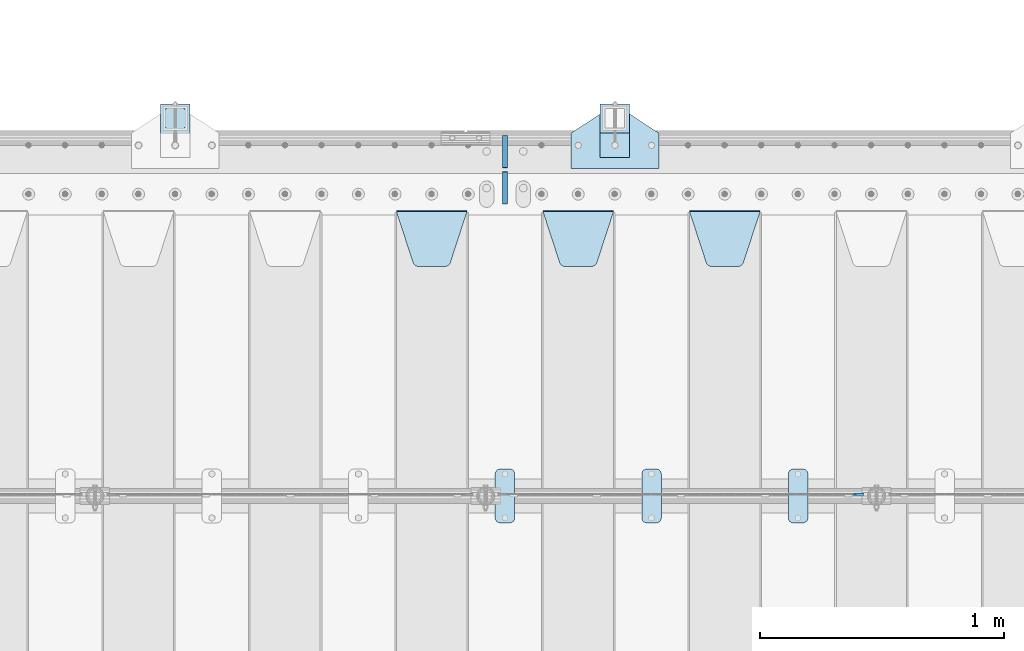
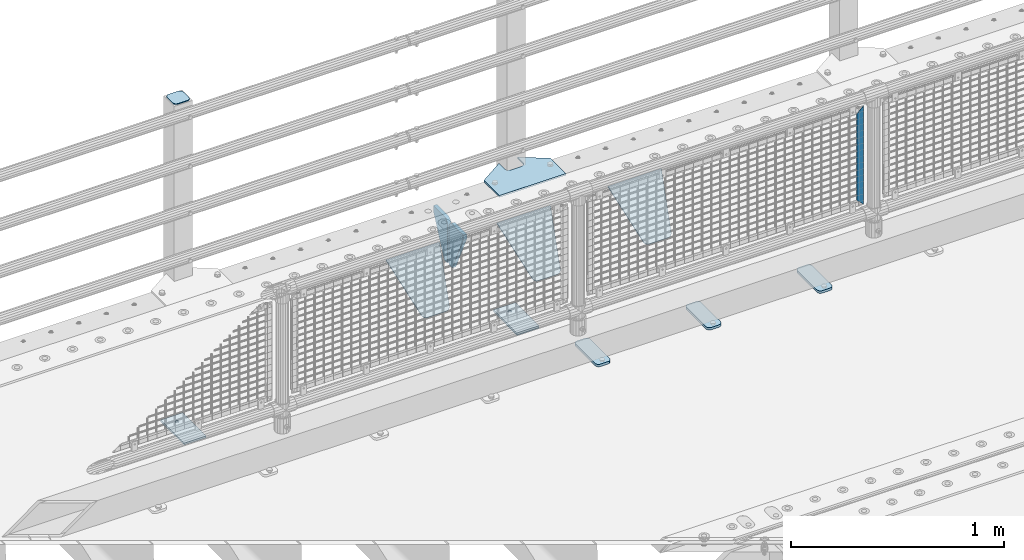
# One storey, part 216 of 247: 14 plates.
"""IFC2X3 building model written with IfcOpenShell, lengths in millimetres."""

from ifc_helpers import new_model, si_unit, frame, origin_with_axes, place, context, subcontext, project, spatial, faceted_brep, material, type_object, element, save


model = new_model("IFC2X3")

# Units and contexts
model_context = context("Model", 3, precision=1e-05, world=origin_with_axes())
body_context = subcontext(model_context, "Body", "Model", "MODEL_VIEW")
ifc_project = project(units=[si_unit("LENGTHUNIT", "METRE", prefix="MILLI"), si_unit("AREAUNIT", "SQUARE_METRE"), si_unit("VOLUMEUNIT", "CUBIC_METRE"), si_unit("MASSUNIT", "GRAM", prefix="KILO"), si_unit("TIMEUNIT", "SECOND"), si_unit("PLANEANGLEUNIT", "RADIAN"), si_unit("SOLIDANGLEUNIT", "STERADIAN"), si_unit("THERMODYNAMICTEMPERATUREUNIT", "DEGREE_CELSIUS"), si_unit("LUMINOUSINTENSITYUNIT", "LUMEN")], contexts=[model_context])

# Site, building, storey
site_placement = place(None, origin_with_axes())
site = spatial("IfcSite", under=ifc_project, at=site_placement, CompositionType="ELEMENT")
building_placement = place(site_placement, origin_with_axes())
building = spatial("IfcBuilding", under=site, at=building_placement, Name="Standard", CompositionType="ELEMENT")
storey_placement = place(building_placement, origin_with_axes())
storey = spatial("IfcBuildingStorey", under=building, at=storey_placement, Name="Undefined", CompositionType="ELEMENT", Elevation=0.0)

# Plates
ifc_material_1 = material(Name="STEEL/S355J2")
plate_type_1 = type_object("IfcPlateType", PredefinedType="NOTDEFINED")
plate_1_placement = place(storey_placement, frame((6660.0, 7774.5, 21.0199999999977), z_axis=(1.0, 0.0, 0.0), x_axis=(0.0, -0.999999999999548, -9.5100000000016e-07)))
element("IfcPlate", 1, at=plate_1_placement, inside=storey, type_object=plate_type_1, material=ifc_material_1, context=body_context, shape_type="Brep", body=[
    faceted_brep([(0.0, -7.0, 20.0), (0.0, -7.0, 60.0), (0.0, 7.0, 60.0), (0.0, 7.0, 20.0), (0.384294391935327, -7.0, 63.9018064403226), (0.384294391935327, 7.0, 63.9018064403226), (1.52240934977453, -7.0, 67.6536686473009), (1.52240934977453, 7.0, 67.6536686473009), (3.37060775394912, -7.0, 71.1114046603925), (3.37060775394912, 7.0, 71.1114046603925), (5.85786437626939, -7.0, 74.1421356237315), (5.85786437626939, 7.0, 74.1421356237315), (8.8885953396084, -7.0, 76.6293922460518), (8.8885953396084, 7.0, 76.6293922460518), (12.3463313526981, -7.0, 78.4775906502255), (12.3463313526981, 7.0, 78.4775906502255), (16.0981935596774, -7.0, 79.6157056080647), (16.0981935596774, 7.0, 79.6157056080647), (20.0, -7.0, 80.0), (20.0, 7.0, 80.0), (200.0, -7.0, 80.0), (200.0, 7.0, 80.0), (203.901806440323, -7.0, 79.6157056080647), (203.901806440323, 7.0, 79.6157056080647), (207.653668647302, -7.0, 78.4775906502255), (207.653668647302, 7.0, 78.4775906502255), (211.111404660392, -7.0, 76.6293922460518), (211.111404660392, 7.0, 76.6293922460518), (214.142135623731, -7.0, 74.1421356237315), (214.142135623731, 7.0, 74.1421356237315), (216.629392246051, -7.0, 71.1114046603925), (216.629392246051, 7.0, 71.1114046603925), (218.477590650225, -7.0, 67.6536686473009), (218.477590650225, 7.0, 67.6536686473009), (219.615705608065, -7.0, 63.9018064403226), (219.615705608065, 7.0, 63.9018064403226), (220.0, -7.0, 60.0), (220.0, 7.0, 60.0), (220.0, -7.0, 20.0), (220.0, 7.0, 20.0), (219.615705608065, -7.0, 16.0981935596774), (219.615705608065, 7.0, 16.0981935596774), (218.477590650225, -7.0, 12.3463313526991), (218.477590650225, 7.0, 12.3463313526991), (216.629392246051, -7.0, 8.88859533960749), (216.629392246051, 7.0, 8.88859533960749), (214.142135623731, -7.0, 5.85786437626848), (214.142135623731, 7.0, 5.85786437626848), (211.111404660392, -7.0, 3.37060775394821), (211.111404660392, 7.0, 3.37060775394821), (207.653668647302, -7.0, 1.52240934977453), (207.653668647302, 7.0, 1.52240934977453), (203.901806440323, -7.0, 0.384294391935327), (203.901806440323, 7.0, 0.384294391935327), (200.0, -7.0, 0.0), (200.0, 7.0, 0.0), (20.0, -7.0, 0.0), (20.0, 7.0, 0.0), (16.0981935596774, -7.0, 0.384294391935327), (16.0981935596774, 7.0, 0.384294391935327), (12.3463313526981, -7.0, 1.52240934977453), (12.3463313526981, 7.0, 1.52240934977453), (8.8885953396084, -7.0, 3.37060775394821), (8.8885953396084, 7.0, 3.37060775394821), (5.85786437626939, -7.0, 5.85786437626848), (5.85786437626939, 7.0, 5.85786437626848), (3.37060775394912, -7.0, 8.88859533960749), (3.37060775394912, 7.0, 8.88859533960749), (1.52240934977453, -7.0, 12.3463313526991), (1.52240934977453, 7.0, 12.3463313526991), (0.384294391935327, -7.0, 16.0981935596774), (0.384294391935327, 7.0, 16.0981935596774)], [[[0, 1, 2, 3]], [[1, 4, 5, 2]], [[4, 6, 7, 5]], [[6, 8, 9, 7]], [[8, 10, 11, 9]], [[10, 12, 13, 11]], [[12, 14, 15, 13]], [[14, 16, 17, 15]], [[16, 18, 19, 17]], [[18, 20, 21, 19]], [[20, 22, 23, 21]], [[22, 24, 25, 23]], [[24, 26, 27, 25]], [[26, 28, 29, 27]], [[28, 30, 31, 29]], [[30, 32, 33, 31]], [[32, 34, 35, 33]], [[34, 36, 37, 35]], [[36, 38, 39, 37]], [[38, 40, 41, 39]], [[40, 42, 43, 41]], [[42, 44, 45, 43]], [[44, 46, 47, 45]], [[46, 48, 49, 47]], [[48, 50, 51, 49]], [[50, 52, 53, 51]], [[52, 54, 55, 53]], [[54, 56, 57, 55]], [[56, 58, 59, 57]], [[58, 60, 61, 59]], [[60, 62, 63, 61]], [[62, 64, 65, 63]], [[64, 66, 67, 65]], [[66, 68, 69, 67]], [[68, 70, 71, 69]], [[70, 0, 3, 71]], [[5, 7, 9, 11, 13, 15, 17, 19, 21, 23, 25, 27, 29, 31, 33, 35, 37, 39, 41, 43, 45, 47, 49, 51, 53, 55, 57, 59, 61, 63, 65, 67, 69, 71, 3, 2]], [[70, 68, 66, 64, 62, 60, 58, 56, 54, 52, 50, 48, 46, 44, 42, 40, 38, 36, 34, 32, 30, 28, 26, 24, 22, 20, 18, 16, 14, 12, 10, 8, 6, 4, 1, 0]]]),
])
plate_2_placement = place(storey_placement, frame((6060.0, 7774.5, 21.0199999999977), z_axis=(1.0, 0.0, 0.0), x_axis=(0.0, -0.999999999999548, -9.5100000000016e-07)))
element("IfcPlate", 2, at=plate_2_placement, inside=storey, type_object=plate_type_1, material=ifc_material_1, context=body_context, shape_type="Brep", body=[
    faceted_brep([(0.0, -7.0, 20.0), (0.0, -7.0, 60.0), (0.0, 7.0, 60.0), (0.0, 7.0, 20.0), (0.384294391935327, -7.0, 63.9018064403226), (0.384294391935327, 7.0, 63.9018064403226), (1.52240934977453, -7.0, 67.6536686473009), (1.52240934977453, 7.0, 67.6536686473009), (3.37060775394912, -7.0, 71.1114046603925), (3.37060775394912, 7.0, 71.1114046603925), (5.85786437626939, -7.0, 74.1421356237315), (5.85786437626939, 7.0, 74.1421356237315), (8.8885953396084, -7.0, 76.6293922460518), (8.8885953396084, 7.0, 76.6293922460518), (12.3463313526981, -7.0, 78.4775906502255), (12.3463313526981, 7.0, 78.4775906502255), (16.0981935596774, -7.0, 79.6157056080647), (16.0981935596774, 7.0, 79.6157056080647), (20.0, -7.0, 80.0), (20.0, 7.0, 80.0), (200.0, -7.0, 80.0), (200.0, 7.0, 80.0), (203.901806440323, -7.0, 79.6157056080647), (203.901806440323, 7.0, 79.6157056080647), (207.653668647302, -7.0, 78.4775906502255), (207.653668647302, 7.0, 78.4775906502255), (211.111404660392, -7.0, 76.6293922460518), (211.111404660392, 7.0, 76.6293922460518), (214.142135623731, -7.0, 74.1421356237315), (214.142135623731, 7.0, 74.1421356237315), (216.629392246051, -7.0, 71.1114046603925), (216.629392246051, 7.0, 71.1114046603925), (218.477590650225, -7.0, 67.6536686473009), (218.477590650225, 7.0, 67.6536686473009), (219.615705608065, -7.0, 63.9018064403226), (219.615705608065, 7.0, 63.9018064403226), (220.0, -7.0, 60.0), (220.0, 7.0, 60.0), (220.0, -7.0, 20.0), (220.0, 7.0, 20.0), (219.615705608065, -7.0, 16.0981935596774), (219.615705608065, 7.0, 16.0981935596774), (218.477590650225, -7.0, 12.3463313526991), (218.477590650225, 7.0, 12.3463313526991), (216.629392246051, -7.0, 8.88859533960749), (216.629392246051, 7.0, 8.88859533960749), (214.142135623731, -7.0, 5.85786437626848), (214.142135623731, 7.0, 5.85786437626848), (211.111404660392, -7.0, 3.37060775394821), (211.111404660392, 7.0, 3.37060775394821), (207.653668647302, -7.0, 1.52240934977453), (207.653668647302, 7.0, 1.52240934977453), (203.901806440323, -7.0, 0.384294391935327), (203.901806440323, 7.0, 0.384294391935327), (200.0, -7.0, 0.0), (200.0, 7.0, 0.0), (20.0, -7.0, 0.0), (20.0, 7.0, 0.0), (16.0981935596774, -7.0, 0.384294391935327), (16.0981935596774, 7.0, 0.384294391935327), (12.3463313526981, -7.0, 1.52240934977453), (12.3463313526981, 7.0, 1.52240934977453), (8.8885953396084, -7.0, 3.37060775394821), (8.8885953396084, 7.0, 3.37060775394821), (5.85786437626939, -7.0, 5.85786437626848), (5.85786437626939, 7.0, 5.85786437626848), (3.37060775394912, -7.0, 8.88859533960749), (3.37060775394912, 7.0, 8.88859533960749), (1.52240934977453, -7.0, 12.3463313526991), (1.52240934977453, 7.0, 12.3463313526991), (0.384294391935327, -7.0, 16.0981935596774), (0.384294391935327, 7.0, 16.0981935596774)], [[[0, 1, 2, 3]], [[1, 4, 5, 2]], [[4, 6, 7, 5]], [[6, 8, 9, 7]], [[8, 10, 11, 9]], [[10, 12, 13, 11]], [[12, 14, 15, 13]], [[14, 16, 17, 15]], [[16, 18, 19, 17]], [[18, 20, 21, 19]], [[20, 22, 23, 21]], [[22, 24, 25, 23]], [[24, 26, 27, 25]], [[26, 28, 29, 27]], [[28, 30, 31, 29]], [[30, 32, 33, 31]], [[32, 34, 35, 33]], [[34, 36, 37, 35]], [[36, 38, 39, 37]], [[38, 40, 41, 39]], [[40, 42, 43, 41]], [[42, 44, 45, 43]], [[44, 46, 47, 45]], [[46, 48, 49, 47]], [[48, 50, 51, 49]], [[50, 52, 53, 51]], [[52, 54, 55, 53]], [[54, 56, 57, 55]], [[56, 58, 59, 57]], [[58, 60, 61, 59]], [[60, 62, 63, 61]], [[62, 64, 65, 63]], [[64, 66, 67, 65]], [[66, 68, 69, 67]], [[68, 70, 71, 69]], [[70, 0, 3, 71]], [[5, 7, 9, 11, 13, 15, 17, 19, 21, 23, 25, 27, 29, 31, 33, 35, 37, 39, 41, 43, 45, 47, 49, 51, 53, 55, 57, 59, 61, 63, 65, 67, 69, 71, 3, 2]], [[70, 68, 66, 64, 62, 60, 58, 56, 54, 52, 50, 48, 46, 44, 42, 40, 38, 36, 34, 32, 30, 28, 26, 24, 22, 20, 18, 16, 14, 12, 10, 8, 6, 4, 1, 0]]]),
])
plate_3_placement = place(storey_placement, frame((5460.0, 7774.5, 21.0199999999977), z_axis=(1.0, 0.0, 0.0), x_axis=(0.0, -0.999999999999548, -9.5100000000016e-07)))
element("IfcPlate", 3, at=plate_3_placement, inside=storey, type_object=plate_type_1, material=ifc_material_1, context=body_context, shape_type="Brep", body=[
    faceted_brep([(0.0, -7.0, 20.0), (0.0, -7.0, 60.0), (0.0, 7.0, 60.0), (0.0, 7.0, 20.0), (0.384294391935327, -7.0, 63.9018064403226), (0.384294391935327, 7.0, 63.9018064403226), (1.52240934977453, -7.0, 67.6536686473009), (1.52240934977453, 7.0, 67.6536686473009), (3.37060775394912, -7.0, 71.1114046603925), (3.37060775394912, 7.0, 71.1114046603925), (5.85786437626939, -7.0, 74.1421356237315), (5.85786437626939, 7.0, 74.1421356237315), (8.8885953396084, -7.0, 76.6293922460518), (8.8885953396084, 7.0, 76.6293922460518), (12.3463313526981, -7.0, 78.4775906502255), (12.3463313526981, 7.0, 78.4775906502255), (16.0981935596774, -7.0, 79.6157056080647), (16.0981935596774, 7.0, 79.6157056080647), (20.0, -7.0, 80.0), (20.0, 7.0, 80.0), (200.0, -7.0, 80.0), (200.0, 7.0, 80.0), (203.901806440323, -7.0, 79.6157056080647), (203.901806440323, 7.0, 79.6157056080647), (207.653668647302, -7.0, 78.4775906502255), (207.653668647302, 7.0, 78.4775906502255), (211.111404660392, -7.0, 76.6293922460518), (211.111404660392, 7.0, 76.6293922460518), (214.142135623731, -7.0, 74.1421356237315), (214.142135623731, 7.0, 74.1421356237315), (216.629392246051, -7.0, 71.1114046603925), (216.629392246051, 7.0, 71.1114046603925), (218.477590650225, -7.0, 67.6536686473009), (218.477590650225, 7.0, 67.6536686473009), (219.615705608065, -7.0, 63.9018064403226), (219.615705608065, 7.0, 63.9018064403226), (220.0, -7.0, 60.0), (220.0, 7.0, 60.0), (220.0, -7.0, 20.0), (220.0, 7.0, 20.0), (219.615705608065, -7.0, 16.0981935596774), (219.615705608065, 7.0, 16.0981935596774), (218.477590650225, -7.0, 12.3463313526991), (218.477590650225, 7.0, 12.3463313526991), (216.629392246051, -7.0, 8.88859533960749), (216.629392246051, 7.0, 8.88859533960749), (214.142135623731, -7.0, 5.85786437626848), (214.142135623731, 7.0, 5.85786437626848), (211.111404660392, -7.0, 3.37060775394821), (211.111404660392, 7.0, 3.37060775394821), (207.653668647302, -7.0, 1.52240934977453), (207.653668647302, 7.0, 1.52240934977453), (203.901806440323, -7.0, 0.384294391935327), (203.901806440323, 7.0, 0.384294391935327), (200.0, -7.0, 0.0), (200.0, 7.0, 0.0), (20.0, -7.0, 0.0), (20.0, 7.0, 0.0), (16.0981935596774, -7.0, 0.384294391935327), (16.0981935596774, 7.0, 0.384294391935327), (12.3463313526981, -7.0, 1.52240934977453), (12.3463313526981, 7.0, 1.52240934977453), (8.8885953396084, -7.0, 3.37060775394821), (8.8885953396084, 7.0, 3.37060775394821), (5.85786437626939, -7.0, 5.85786437626848), (5.85786437626939, 7.0, 5.85786437626848), (3.37060775394912, -7.0, 8.88859533960749), (3.37060775394912, 7.0, 8.88859533960749), (1.52240934977453, -7.0, 12.3463313526991), (1.52240934977453, 7.0, 12.3463313526991), (0.384294391935327, -7.0, 16.0981935596774), (0.384294391935327, 7.0, 16.0981935596774)], [[[0, 1, 2, 3]], [[1, 4, 5, 2]], [[4, 6, 7, 5]], [[6, 8, 9, 7]], [[8, 10, 11, 9]], [[10, 12, 13, 11]], [[12, 14, 15, 13]], [[14, 16, 17, 15]], [[16, 18, 19, 17]], [[18, 20, 21, 19]], [[20, 22, 23, 21]], [[22, 24, 25, 23]], [[24, 26, 27, 25]], [[26, 28, 29, 27]], [[28, 30, 31, 29]], [[30, 32, 33, 31]], [[32, 34, 35, 33]], [[34, 36, 37, 35]], [[36, 38, 39, 37]], [[38, 40, 41, 39]], [[40, 42, 43, 41]], [[42, 44, 45, 43]], [[44, 46, 47, 45]], [[46, 48, 49, 47]], [[48, 50, 51, 49]], [[50, 52, 53, 51]], [[52, 54, 55, 53]], [[54, 56, 57, 55]], [[56, 58, 59, 57]], [[58, 60, 61, 59]], [[60, 62, 63, 61]], [[62, 64, 65, 63]], [[64, 66, 67, 65]], [[66, 68, 69, 67]], [[68, 70, 71, 69]], [[70, 0, 3, 71]], [[5, 7, 9, 11, 13, 15, 17, 19, 21, 23, 25, 27, 29, 31, 33, 35, 37, 39, 41, 43, 45, 47, 49, 51, 53, 55, 57, 59, 61, 63, 65, 67, 69, 71, 3, 2]], [[70, 68, 66, 64, 62, 60, 58, 56, 54, 52, 50, 48, 46, 44, 42, 40, 38, 36, 34, 32, 30, 28, 26, 24, 22, 20, 18, 16, 14, 12, 10, 8, 6, 4, 1, 0]]]),
])
ifc_material_2 = material(Name="STEEL/S355N")
plate_type_2 = type_object("IfcPlateType", PredefinedType="NOTDEFINED")
plate_4_placement = place(storey_placement, frame((6255.0, 8831.76776695594, -1.767766952965), z_axis=(0.0, -0.707106781186548, -0.707106781186547), x_axis=(1.0, 0.0, 0.0)))
element("IfcPlate", 4, at=plate_4_placement, inside=storey, type_object=plate_type_2, material=ifc_material_2, context=body_context, shape_type="Brep", body=[
    faceted_brep([(0.0, -2.49999999999909, 0.0), (69.345504679477, -2.5, 300.17173142483), (69.345504679477, 2.50000000000091, 300.171731424831), (0.0, 2.5, -9.09494701772928e-13), (70.9274061199576, -2.5, 304.897442415399), (70.9274061199576, 2.50000000000091, 304.8974424154), (73.3818627772307, -2.49999999999909, 309.234538108527), (73.3818627772307, 2.5, 309.234538108526), (76.6187032999551, -2.5, 313.023683126102), (76.6187032999551, 2.50000000000091, 313.023683126102), (80.5190132704993, -2.49999999999909, 316.125672595371), (80.5190132704993, 2.50000000000091, 316.125672595372), (84.9395038596849, -2.49999999999909, 318.426546230476), (84.9395038596849, 2.5, 318.426546230475), (89.7177759439219, -2.5, 319.841774983274), (89.7177759439219, 2.50000000000091, 319.841774983275), (94.678286292652, -2.5, 320.319366455077), (94.678286292652, 2.50000000000091, 320.319366455077), (195.321713707348, -2.5, 320.319366455077), (195.321713707348, 2.50000000000091, 320.319366455077), (200.282224056078, -2.5, 319.841774983274), (200.282224056078, 2.50000000000091, 319.841774983275), (205.060496140315, -2.5, 318.426546230475), (205.060496140315, 2.5, 318.426546230474), (209.480986729501, -2.49999999999818, 316.12567259537), (209.480986729501, 2.50000000000091, 316.12567259537), (213.381296700045, -2.5, 313.023683126101), (213.381296700045, 2.50000000000091, 313.023683126101), (216.618137222769, -2.5, 309.234538108525), (216.618137222769, 2.5, 309.234538108525), (219.072593880042, -2.49999999999909, 304.897442415398), (219.072593880042, 2.5, 304.897442415398), (220.654495320523, -2.5, 300.17173142483), (220.654495320523, 2.50000000000091, 300.171731424831), (290.0, -2.49999999999909, 0.0), (290.0, 2.5, -9.09494701772928e-13)], [[[0, 1, 2, 3]], [[1, 4, 5, 2]], [[4, 6, 7, 5]], [[6, 8, 9, 7]], [[8, 10, 11, 9]], [[10, 12, 13, 11]], [[12, 14, 15, 13]], [[14, 16, 17, 15]], [[16, 18, 19, 17]], [[18, 20, 21, 19]], [[20, 22, 23, 21]], [[22, 24, 25, 23]], [[24, 26, 27, 25]], [[26, 28, 29, 27]], [[28, 30, 31, 29]], [[30, 32, 33, 31]], [[32, 34, 35, 33]], [[34, 0, 3, 35]], [[5, 7, 9, 11, 13, 15, 17, 19, 21, 23, 25, 27, 29, 31, 33, 35, 3, 2]], [[34, 32, 30, 28, 26, 24, 22, 20, 18, 16, 14, 12, 10, 8, 6, 4, 1, 0]]]),
])
plate_5_placement = place(storey_placement, frame((5655.0, 8831.76776695594, -1.767766952965), z_axis=(0.0, -0.707106781186548, -0.707106781186547), x_axis=(1.0, 0.0, 0.0)))
element("IfcPlate", 5, at=plate_5_placement, inside=storey, type_object=plate_type_2, material=ifc_material_2, context=body_context, shape_type="Brep", body=[
    faceted_brep([(0.0, -2.49999999999909, 0.0), (69.345504679477, -2.5, 300.17173142483), (69.345504679477, 2.50000000000091, 300.171731424831), (0.0, 2.5, -9.09494701772928e-13), (70.9274061199576, -2.5, 304.897442415399), (70.9274061199576, 2.50000000000091, 304.8974424154), (73.3818627772307, -2.49999999999909, 309.234538108527), (73.3818627772307, 2.5, 309.234538108526), (76.6187032999551, -2.5, 313.023683126102), (76.6187032999551, 2.50000000000091, 313.023683126102), (80.5190132704993, -2.49999999999909, 316.125672595371), (80.5190132704993, 2.50000000000091, 316.125672595372), (84.9395038596849, -2.49999999999909, 318.426546230476), (84.9395038596849, 2.5, 318.426546230475), (89.7177759439219, -2.5, 319.841774983274), (89.7177759439219, 2.50000000000091, 319.841774983275), (94.678286292652, -2.5, 320.319366455077), (94.678286292652, 2.50000000000091, 320.319366455077), (195.321713707348, -2.5, 320.319366455077), (195.321713707348, 2.50000000000091, 320.319366455077), (200.282224056078, -2.5, 319.841774983274), (200.282224056078, 2.50000000000091, 319.841774983275), (205.060496140315, -2.5, 318.426546230475), (205.060496140315, 2.5, 318.426546230474), (209.480986729501, -2.49999999999818, 316.12567259537), (209.480986729501, 2.50000000000091, 316.12567259537), (213.381296700045, -2.5, 313.023683126101), (213.381296700045, 2.50000000000091, 313.023683126101), (216.618137222769, -2.5, 309.234538108525), (216.618137222769, 2.5, 309.234538108525), (219.072593880042, -2.49999999999909, 304.897442415398), (219.072593880042, 2.5, 304.897442415398), (220.654495320523, -2.5, 300.17173142483), (220.654495320523, 2.50000000000091, 300.171731424831), (290.0, -2.49999999999909, 0.0), (290.0, 2.5, -9.09494701772928e-13)], [[[0, 1, 2, 3]], [[1, 4, 5, 2]], [[4, 6, 7, 5]], [[6, 8, 9, 7]], [[8, 10, 11, 9]], [[10, 12, 13, 11]], [[12, 14, 15, 13]], [[14, 16, 17, 15]], [[16, 18, 19, 17]], [[18, 20, 21, 19]], [[20, 22, 23, 21]], [[22, 24, 25, 23]], [[24, 26, 27, 25]], [[26, 28, 29, 27]], [[28, 30, 31, 29]], [[30, 32, 33, 31]], [[32, 34, 35, 33]], [[34, 0, 3, 35]], [[5, 7, 9, 11, 13, 15, 17, 19, 21, 23, 25, 27, 29, 31, 33, 35, 3, 2]], [[34, 32, 30, 28, 26, 24, 22, 20, 18, 16, 14, 12, 10, 8, 6, 4, 1, 0]]]),
])
plate_6_placement = place(storey_placement, frame((5055.0, 8831.76776695594, -1.767766952965), z_axis=(0.0, -0.707106781186548, -0.707106781186547), x_axis=(1.0, 0.0, 0.0)))
element("IfcPlate", 6, at=plate_6_placement, inside=storey, type_object=plate_type_2, material=ifc_material_2, context=body_context, shape_type="Brep", body=[
    faceted_brep([(0.0, -2.49999999999909, 0.0), (69.345504679477, -2.5, 300.17173142483), (69.345504679477, 2.50000000000091, 300.171731424831), (0.0, 2.5, -9.09494701772928e-13), (70.9274061199576, -2.5, 304.897442415399), (70.9274061199576, 2.50000000000091, 304.8974424154), (73.3818627772307, -2.49999999999909, 309.234538108527), (73.3818627772307, 2.5, 309.234538108526), (76.6187032999551, -2.5, 313.023683126102), (76.6187032999551, 2.50000000000091, 313.023683126102), (80.5190132704993, -2.49999999999909, 316.125672595371), (80.5190132704993, 2.50000000000091, 316.125672595372), (84.9395038596849, -2.49999999999909, 318.426546230476), (84.9395038596849, 2.5, 318.426546230475), (89.7177759439219, -2.5, 319.841774983274), (89.7177759439219, 2.50000000000091, 319.841774983275), (94.678286292652, -2.5, 320.319366455077), (94.678286292652, 2.50000000000091, 320.319366455077), (195.321713707348, -2.5, 320.319366455077), (195.321713707348, 2.50000000000091, 320.319366455077), (200.282224056078, -2.5, 319.841774983274), (200.282224056078, 2.50000000000091, 319.841774983275), (205.060496140315, -2.5, 318.426546230475), (205.060496140315, 2.5, 318.426546230474), (209.480986729501, -2.49999999999818, 316.12567259537), (209.480986729501, 2.50000000000091, 316.12567259537), (213.381296700045, -2.5, 313.023683126101), (213.381296700045, 2.50000000000091, 313.023683126101), (216.618137222769, -2.5, 309.234538108525), (216.618137222769, 2.5, 309.234538108525), (219.072593880042, -2.49999999999909, 304.897442415398), (219.072593880042, 2.5, 304.897442415398), (220.654495320523, -2.5, 300.17173142483), (220.654495320523, 2.50000000000091, 300.171731424831), (290.0, -2.49999999999909, 0.0), (290.0, 2.5, -9.09494701772928e-13)], [[[0, 1, 2, 3]], [[1, 4, 5, 2]], [[4, 6, 7, 5]], [[6, 8, 9, 7]], [[8, 10, 11, 9]], [[10, 12, 13, 11]], [[12, 14, 15, 13]], [[14, 16, 17, 15]], [[16, 18, 19, 17]], [[18, 20, 21, 19]], [[20, 22, 23, 21]], [[22, 24, 25, 23]], [[24, 26, 27, 25]], [[26, 28, 29, 27]], [[28, 30, 31, 29]], [[30, 32, 33, 31]], [[32, 34, 35, 33]], [[34, 0, 3, 35]], [[5, 7, 9, 11, 13, 15, 17, 19, 21, 23, 25, 27, 29, 31, 33, 35, 3, 2]], [[34, 32, 30, 28, 26, 24, 22, 20, 18, 16, 14, 12, 10, 8, 6, 4, 1, 0]]]),
])
ifc_material_3 = material(Name="Misc_Undefined")
plate_type_3 = type_object("IfcPlateType", PredefinedType="NOTDEFINED")
plate_7_placement = place(storey_placement, frame((6932.49968748361, 7670.5, 879.52), z_axis=(0.707103624179499, 0.0, -0.707109938179501), x_axis=(0.707109938179497, 0.0, 0.707103624179503)))
element("IfcPlate", 7, at=plate_7_placement, inside=storey, type_object=plate_type_3, material=ifc_material_3, context=body_context, shape_type="Brep", body=[
    faceted_brep([(1.81898940354586e-12, -1.5, -5.6843418860808e-14), (-348.605163574215, -1.5, 348.60208129883), (-348.605163574215, 1.5, 348.60208129883), (1.81898940354586e-12, 1.5, -5.6843418860808e-14), (-348.605163574215, -1.5, 398.099334716799), (-348.605163574215, 1.5, 398.099334716799), (49.4976959228497, -1.5, 7.09405867382884e-11), (49.4976959228497, 1.5, 7.09405867382884e-11)], [[[0, 1, 2, 3]], [[1, 4, 5, 2]], [[4, 6, 7, 5]], [[6, 0, 3, 7]], [[5, 7, 3, 2]], [[6, 4, 1, 0]]]),
])
plate_type_4 = type_object("IfcPlateType", PredefinedType="NOTDEFINED")
for number, where, z_axis, x_axis in (
    (8, (5500.0, 9140.0, -30.0), (0.0, 0.0, -1.0), (0.0, -0.999999999999548, -9.5100000000016e-07)),
    (9, (5500.0, 8860.0, -30.0), (0.0, 0.0, -1.0), (0.0, 1.0, 0.0)),
):
    element("IfcPlate", number, at=place(storey_placement, frame(where, z_axis=z_axis, x_axis=x_axis)), inside=storey, type_object=plate_type_4, material=ifc_material_2, context=body_context, shape_type="Brep", body=[
        faceted_brep([(-5.6843418860808e-14, -9.99999999999989, 3.5527136788005e-15), (0.0, -10.0, 30.0), (0.0, 10.0, 30.0), (-5.6843418860808e-14, 10.0000000000001, 3.5527136788005e-15), (102.0, -10.0, 250.0), (102.0, 10.0, 250.0), (132.0, -10.0, 250.0), (132.0, 10.0, 250.0), (132.0, -10.0, 30.0), (132.0, 10.0, 30.0), (131.544232590366, -10.0, 24.790554669992), (131.544232590366, 10.0, 24.790554669992), (130.190778623577, -10.0, 19.7393957002299), (130.190778623577, 10.0, 19.7393957002299), (127.980762113533, -10.0, 15.0), (127.980762113533, 10.0, 15.0), (124.981333293569, -10.0, 10.7163717094038), (124.981333293569, 10.0, 10.7163717094038), (121.283628290596, -10.0, 7.01866670643062), (121.283628290596, 10.0, 7.01866670643062), (117.0, -10.0, 4.01923788646684), (117.0, 10.0, 4.01923788646684), (112.26060429977, -10.0, 1.80922137642278), (112.26060429977, 10.0, 1.80922137642278), (107.209445330008, -10.0, 0.455767409633722), (107.209445330008, 10.0, 0.455767409633722), (102.0, -10.0, 0.0), (102.0, 10.0, 0.0)], [[[0, 1, 2, 3]], [[1, 4, 5, 2]], [[4, 6, 7, 5]], [[6, 8, 9, 7]], [[8, 10, 11, 9]], [[10, 12, 13, 11]], [[12, 14, 15, 13]], [[14, 16, 17, 15]], [[16, 18, 19, 17]], [[18, 20, 21, 19]], [[20, 22, 23, 21]], [[22, 24, 25, 23]], [[24, 26, 27, 25]], [[26, 0, 3, 27]], [[5, 7, 9, 11, 13, 15, 17, 19, 21, 23, 25, 27, 3, 2]], [[26, 24, 22, 20, 18, 16, 14, 12, 10, 8, 6, 4, 1, 0]]]),
    ])
plate_type_5 = type_object("IfcPlateType", PredefinedType="NOTDEFINED")
plate_8_placement = place(storey_placement, frame((5770.0, 9005.0, 5.00000000004911), z_axis=(0.0, 1.0, 0.0), x_axis=(1.0, 0.0, 0.0)))
element("IfcPlate", 10, at=plate_8_placement, inside=storey, type_object=plate_type_5, material=ifc_material_1, context=body_context, shape_type="Brep", body=[
    faceted_brep([(9.04219632502645e-09, -5.00000000143385, -2.89173840428703e-09), (2.31396552408114e-06, -5.0, 145.0), (2.31396552408114e-06, 5.0, 145.0), (7.66340235713869e-09, 4.99999999856618, -2.89173840428703e-09), (130.0, -5.0, 230.0), (130.0, 5.0, 230.0), (130.0, -5.0, 180.0), (130.0, 5.0, 180.0), (130.48036798992, -5.0, 175.122741949597), (130.48036798992, 5.0, 175.122741949597), (131.903011687218, -5.0, 170.432914190873), (131.903011687218, 5.0, 170.432914190873), (134.213259692437, -5.0, 166.11074417451), (134.213259692437, 5.0, 166.11074417451), (137.322330470337, -5.0, 162.322330470337), (137.322330470337, 5.0, 162.322330470337), (141.11074417451, -5.0, 159.213259692437), (141.11074417451, 5.0, 159.213259692437), (145.432914190873, -5.0, 156.903011687218), (145.432914190873, 5.0, 156.903011687218), (150.122741949597, -5.0, 155.48036798992), (150.122741949597, 5.0, 155.48036798992), (155.0, -5.0, 155.0), (155.0, 5.0, 155.0), (205.0, -5.0, 155.0), (205.0, 5.0, 155.0), (209.877258050403, -5.0, 155.48036798992), (209.877258050403, 5.0, 155.48036798992), (214.567085809127, -5.0, 156.903011687218), (214.567085809127, 5.0, 156.903011687218), (218.88925582549, -5.0, 159.213259692437), (218.88925582549, 5.0, 159.213259692437), (222.677669529663, -5.0, 162.322330470337), (222.677669529663, 5.0, 162.322330470337), (225.786740307563, -5.0, 166.11074417451), (225.786740307563, 5.0, 166.11074417451), (228.096988312782, -5.0, 170.432914190873), (228.096988312782, 5.0, 170.432914190873), (229.51963201008, -5.0, 175.122741949597), (229.51963201008, 5.0, 175.122741949597), (230.0, -5.0, 180.0), (230.0, 5.0, 180.0), (230.0, -5.0, 230.0), (230.0, 5.0, 230.0), (360.0, -5.0, 145.0), (360.0, 5.0, 145.0), (360.0, -5.0, -7.27595761418343e-12), (360.0, 5.0, -7.27595761418343e-12)], [[[0, 1, 2, 3]], [[1, 4, 5, 2]], [[4, 6, 7, 5]], [[6, 8, 9, 7]], [[8, 10, 11, 9]], [[10, 12, 13, 11]], [[12, 14, 15, 13]], [[14, 16, 17, 15]], [[16, 18, 19, 17]], [[18, 20, 21, 19]], [[20, 22, 23, 21]], [[22, 24, 25, 23]], [[24, 26, 27, 25]], [[26, 28, 29, 27]], [[28, 30, 31, 29]], [[30, 32, 33, 31]], [[32, 34, 35, 33]], [[34, 36, 37, 35]], [[36, 38, 39, 37]], [[38, 40, 41, 39]], [[40, 42, 43, 41]], [[42, 44, 45, 43]], [[44, 46, 47, 45]], [[46, 0, 3, 47]], [[5, 7, 9, 11, 13, 15, 17, 19, 21, 23, 25, 27, 29, 31, 33, 35, 37, 39, 41, 43, 45, 47, 3, 2]], [[46, 44, 42, 40, 38, 36, 34, 32, 30, 28, 26, 24, 22, 20, 18, 16, 14, 12, 10, 8, 6, 4, 1, 0]]]),
])
plate_type_6 = type_object("IfcPlateType", PredefinedType="NOTDEFINED")
for number, where, z_axis, x_axis in (
    (11, (5890.00000000014, 9050.00000000021, -850.000000000002), (0.0, 1.0, 0.0), (1.0, 0.0, 0.0)),
    (12, (4090.00000000014, 9050.00000000021, -850.000000000002), (0.0, 1.0, 0.0), (1.0, 0.0, 0.0)),
):
    element("IfcPlate", number, at=place(storey_placement, frame(where, z_axis=z_axis, x_axis=x_axis)), inside=storey, type_object=plate_type_6, material=ifc_material_1, context=body_context, shape_type="Brep", body=[
        faceted_brep([(66.3639610305399, -5.0, 163.636038969113), (66.3639610305399, 5.0, 163.636038969113), (59.9999999998618, 5.0, 160.999999999791), (59.9999999998618, -5.0, 160.999999999791), (53.6360389691836, 5.0, 163.636038969113), (53.6360389691836, -5.0, 163.636038969113), (50.9999999998618, 5.0, 169.999999999791), (50.9999999998618, -5.0, 169.999999999791), (53.6360389691836, 5.0, 176.363961030469), (53.6360389691836, -5.0, 176.363961030469), (59.9999999998618, 5.0, 178.999999999791), (59.9999999998618, -5.0, 178.999999999791), (66.3639610305399, 5.0, 176.363961030469), (66.3639610305399, -5.0, 176.363961030469), (68.9999999998618, 5.0, 169.999999999791), (68.9999999998618, -5.0, 169.999999999791), (120.0, -5.0, 0.0), (120.0, -5.0, 220.0), (0.0, -5.0, 220.0), (9.04219632502645e-09, -5.00000000143385, -2.89173840428703e-09), (7.66340235713869e-09, 4.99999999856618, -2.89173840428703e-09), (120.0, 5.0, 0.0), (120.0, 5.0, 220.0), (0.0, 5.0, 220.0)], [[[0, 1, 2, 3]], [[3, 2, 4, 5]], [[5, 4, 6, 7]], [[7, 6, 8, 9]], [[9, 8, 10, 11]], [[11, 10, 12, 13]], [[13, 12, 14, 15]], [[15, 14, 1, 0]], [[16, 17, 18, 19], [3, 5, 7, 9, 11, 13, 15, 0]], [[16, 19, 20, 21]], [[17, 16, 21, 22]], [[18, 17, 22, 23]], [[19, 18, 23, 20]], [[22, 21, 20, 23], [10, 8, 6, 4, 2, 1, 14, 12]]]),
    ])
plate_type_7 = type_object("IfcPlateType", PredefinedType="NOTDEFINED")
plate_9_placement = place(storey_placement, frame((4194.00000000013, 9166.00000000021, 1012.50000000001), z_axis=(0.0, 1.0, 0.0), x_axis=(-1.0, 0.0, 0.0)))
element("IfcPlate", 13, at=plate_9_placement, inside=storey, type_object=plate_type_7, material=ifc_material_1, context=body_context, shape_type="Brep", body=[
    faceted_brep([(0.0, -2.5, 19.0), (0.0, -2.5, 69.0), (0.0, 2.5, 69.0), (0.0, 2.5, 19.0), (0.476369668545885, -2.5, 73.2278977451697), (0.476369668545885, 2.5, 73.2278977451697), (1.88159150985484, -2.5, 77.2437910432327), (1.88159150985484, 2.5, 77.2437910432327), (4.14520183310742, -2.5, 80.8463062353167), (4.14520183310742, 2.5, 80.8463062353167), (7.15369376468334, -2.5, 83.8547981668926), (7.15369376468334, 2.5, 83.8547981668926), (10.7562089567673, -2.5, 86.1184084901452), (10.7562089567673, 2.5, 86.1184084901452), (14.7721022548303, -2.5, 87.5236303314541), (14.7721022548303, 2.5, 87.5236303314541), (19.0, -2.5, 88.0), (19.0, 2.5, 88.0), (69.0, -2.5, 88.0), (69.0, 2.5, 88.0), (73.2278977451697, -2.5, 87.5236303314541), (73.2278977451697, 2.5, 87.5236303314541), (77.2437910432327, -2.5, 86.1184084901452), (77.2437910432327, 2.5, 86.1184084901452), (80.8463062353167, -2.5, 83.8547981668926), (80.8463062353167, 2.5, 83.8547981668926), (83.8547981668926, -2.5, 80.8463062353167), (83.8547981668926, 2.5, 80.8463062353167), (86.1184084901452, -2.5, 77.2437910432327), (86.1184084901452, 2.5, 77.2437910432327), (87.5236303314541, -2.5, 73.2278977451697), (87.5236303314541, 2.5, 73.2278977451697), (88.0, -2.5, 69.0), (88.0, 2.5, 69.0), (88.0, -2.5, 19.0), (88.0, 2.5, 19.0), (87.5236303314541, -2.5, 14.7721022548303), (87.5236303314541, 2.5, 14.7721022548303), (86.1184084901452, -2.5, 10.7562089567673), (86.1184084901452, 2.5, 10.7562089567673), (83.8547981668926, -2.5, 7.15369376468334), (83.8547981668926, 2.5, 7.15369376468334), (80.8463062353167, -2.5, 4.14520183310742), (80.8463062353167, 2.5, 4.14520183310742), (77.2437910432345, -2.5, 1.88159150985484), (77.2437910432345, 2.5, 1.88159150985484), (73.2278977451697, -2.5, 0.476369668545885), (73.2278977451697, 2.5, 0.476369668545885), (69.0, -2.5, 0.0), (69.0, 2.5, 0.0), (19.0, -2.5, 0.0), (19.0, 2.5, 0.0), (14.7721022548303, -2.5, 0.476369668545885), (14.7721022548303, 2.5, 0.476369668545885), (10.7562089567673, -2.5, 1.88159150985484), (10.7562089567673, 2.5, 1.88159150985484), (7.15369376468334, -2.5, 4.14520183310742), (7.15369376468334, 2.5, 4.14520183310742), (4.14520183310742, -2.5, 7.15369376468334), (4.14520183310742, 2.5, 7.15369376468334), (1.88159150985484, -2.5, 10.7562089567673), (1.88159150985484, 2.5, 10.7562089567673), (0.476369668545885, -2.5, 14.7721022548303), (0.476369668545885, 2.5, 14.7721022548303)], [[[0, 1, 2, 3]], [[1, 4, 5, 2]], [[4, 6, 7, 5]], [[6, 8, 9, 7]], [[8, 10, 11, 9]], [[10, 12, 13, 11]], [[12, 14, 15, 13]], [[14, 16, 17, 15]], [[16, 18, 19, 17]], [[18, 20, 21, 19]], [[20, 22, 23, 21]], [[22, 24, 25, 23]], [[24, 26, 27, 25]], [[26, 28, 29, 27]], [[28, 30, 31, 29]], [[30, 32, 33, 31]], [[32, 34, 35, 33]], [[34, 36, 37, 35]], [[36, 38, 39, 37]], [[38, 40, 41, 39]], [[40, 42, 43, 41]], [[42, 44, 45, 43]], [[44, 46, 47, 45]], [[46, 48, 49, 47]], [[48, 50, 51, 49]], [[50, 52, 53, 51]], [[52, 54, 55, 53]], [[54, 56, 57, 55]], [[56, 58, 59, 57]], [[58, 60, 61, 59]], [[60, 62, 63, 61]], [[62, 0, 3, 63]], [[5, 7, 9, 11, 13, 15, 17, 19, 21, 23, 25, 27, 29, 31, 33, 35, 37, 39, 41, 43, 45, 47, 49, 51, 53, 55, 57, 59, 61, 63, 3, 2]], [[62, 60, 58, 56, 54, 52, 50, 48, 46, 44, 42, 40, 38, 36, 34, 32, 30, 28, 26, 24, 22, 20, 18, 16, 14, 12, 10, 8, 6, 4, 1, 0]]]),
])
plate_type_8 = type_object("IfcPlateType", PredefinedType="NOTDEFINED")
plate_10_placement = place(storey_placement, frame((5890.00000000014, 9050.00000000021, -857.500000000002), z_axis=(0.0, 1.0, 0.0), x_axis=(1.0, 0.0, 0.0)))
element("IfcPlate", 14, at=plate_10_placement, inside=storey, type_object=plate_type_8, material=ifc_material_1, context=body_context, shape_type="Brep", body=[
    faceted_brep([(0.0, -2.49999999999909, 0.0), (0.0, -2.5, 100.0), (0.0, 2.5, 100.0), (0.0, 2.5, -9.09494701772928e-13), (120.0, -2.5, 100.0), (120.0, 2.5, 100.0), (120.0, -2.5, 0.0), (120.0, 2.5, 0.0)], [[[0, 1, 2, 3]], [[1, 4, 5, 2]], [[4, 6, 7, 5]], [[6, 0, 3, 7]], [[5, 7, 3, 2]], [[6, 4, 1, 0]]]),
])

save(model, "model.ifc")
